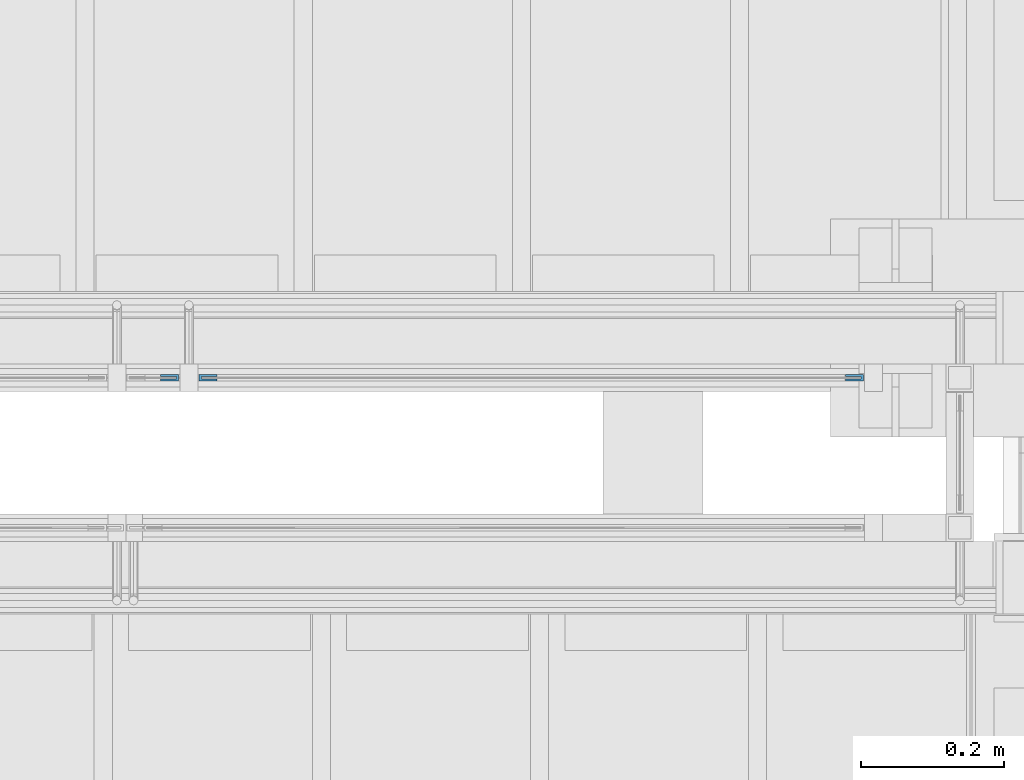
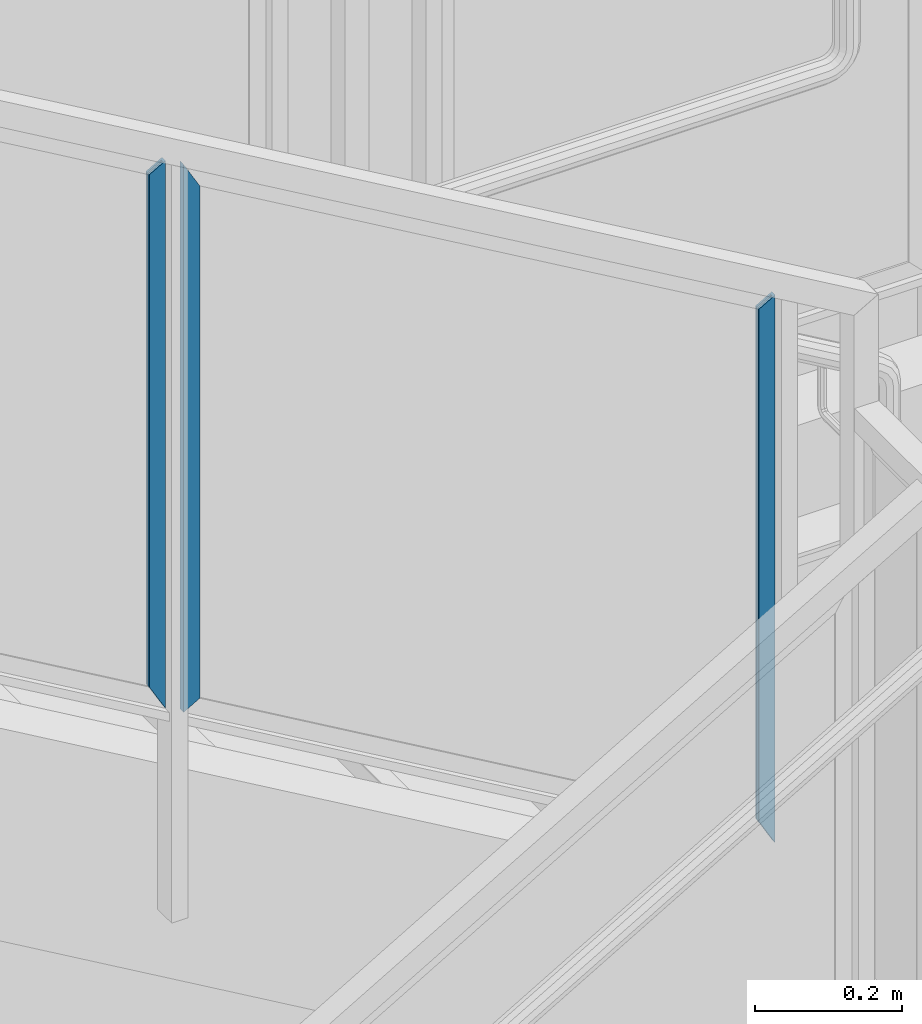
# One storey, part 940 of 1179: 3 beams, 1 element without a shape of its own.
"""IFC2X3 building model written with IfcOpenShell, lengths in millimetres."""

from ifc_helpers import new_model, si_unit, frame, origin_with_axes, place, context, subcontext, project, spatial, faceted_brep, material, type_object, element, aggregate, save


model = new_model("IFC2X3")

# Units and contexts
model_context = context("Model", 3, precision=1e-05, world=origin_with_axes())
body_context = subcontext(model_context, "Body", "Model", "MODEL_VIEW")
ifc_project = project(units=[si_unit("LENGTHUNIT", "METRE", prefix="MILLI"), si_unit("AREAUNIT", "SQUARE_METRE"), si_unit("VOLUMEUNIT", "CUBIC_METRE"), si_unit("MASSUNIT", "GRAM", prefix="KILO"), si_unit("TIMEUNIT", "SECOND"), si_unit("PLANEANGLEUNIT", "RADIAN"), si_unit("SOLIDANGLEUNIT", "STERADIAN"), si_unit("THERMODYNAMICTEMPERATUREUNIT", "DEGREE_CELSIUS"), si_unit("LUMINOUSINTENSITYUNIT", "LUMEN")], contexts=[model_context])

# Site, building, storey
site_placement = place(None, origin_with_axes())
site = spatial("IfcSite", under=ifc_project, at=site_placement, CompositionType="ELEMENT")
building_placement = place(site_placement, origin_with_axes())
building = spatial("IfcBuilding", under=site, at=building_placement, Name="Undefined", CompositionType="ELEMENT")
storey_placement = place(building_placement, origin_with_axes())
storey = spatial("IfcBuildingStorey", under=building, at=storey_placement, Name="Undefined", CompositionType="ELEMENT", Elevation=0.0)

# Assembly, beams
assembly_placement = place(storey_placement, origin_with_axes())
assembly = element("IfcElementAssembly", 1, at=assembly_placement, inside=storey, Name="GUARDRAIL", AssemblyPlace="NOTDEFINED", PredefinedType="RIGID_FRAME")
ifc_material = material(Name="STEEL/BUY-OUT")
beam_type = type_object("IfcBeamType", PredefinedType="NOTDEFINED")
beam_1_placement = place(assembly_placement, frame((21727.2318425017, 39677.9751661883, 7600.2945739131), z_axis=(0.0, 0.0, -1.0), x_axis=(1.0, 0.0, 0.0)))
beam_1 = element("IfcBeam", 2, at=beam_1_placement, type_object=beam_type, material=ifc_material, Name="U-EDGE", context=body_context, shape_type="Brep", body=[
    faceted_brep([(0.0, 1.58750000000146, 410.596656611626), (0.0, -1.58750000000146, 410.596656611626), (22.2250000000131, -1.58750000000146, 449.291208105723), (22.2250000000131, -4.76249999999709, 449.291208105723), (2.91038304567337e-11, -4.76249999999709, 410.596656611676), (2.91038304567337e-11, -7.9375, 410.596656611676), (25.400000000016, -7.9375, 454.819), (25.400000000016, 1.58750000000146, 454.819), (25.400000000016, -7.9375, -454.041889813999), (25.400000000016, 1.58750000000146, -454.041889813999), (0.0, 1.58750000000146, -439.452883390265), (0.0, -1.58750000000146, -439.452883390265), (22.2250000000131, -1.58750000000146, -452.218264011032), (22.2250000000131, -4.76249999999709, -452.218264011032), (2.91038304567337e-11, -4.76249999999709, -439.452883390281), (2.91038304567337e-11, -7.9375, -439.452883390281)], [[[0, 1, 2, 3, 4, 5, 6, 7]], [[7, 6, 8, 9]], [[0, 7, 9, 10]], [[1, 0, 10, 11]], [[2, 1, 11, 12]], [[3, 2, 12, 13]], [[4, 3, 13, 14]], [[5, 4, 14, 15]], [[6, 5, 15, 8]], [[14, 13, 12, 11, 10, 9, 8, 15]]]),
])
beam_2_placement = place(assembly_placement, frame((22683.965176416, 39677.9751661883, 7042.20012977587), z_axis=(0.0, 0.0, -1.0), x_axis=(1.0, 0.0, 0.0)))
beam_2 = element("IfcBeam", 3, at=beam_2_placement, type_object=beam_type, material=ifc_material, Name="U-EDGE", context=body_context, shape_type="Brep", body=[
    faceted_brep([(0.0, 1.58750000000146, 410.596656611626), (0.0, -1.58750000000146, 410.596656611626), (22.2250000000131, -1.58750000000146, 449.291208105723), (22.2250000000131, -4.76249999999709, 449.291208105723), (2.91038304567337e-11, -4.76249999999709, 410.596656611676), (2.91038304567337e-11, -7.9375, 410.596656611676), (25.400000000016, -7.9375, 454.819), (25.400000000016, 1.58750000000146, 454.819), (25.400000000016, -7.9375, -454.041889813999), (25.400000000016, 1.58750000000146, -454.041889813999), (0.0, 1.58750000000146, -439.452883390265), (0.0, -1.58750000000146, -439.452883390265), (22.2250000000131, -1.58750000000146, -452.218264011032), (22.2250000000131, -4.76249999999709, -452.218264011032), (2.91038304567337e-11, -4.76249999999709, -439.452883390281), (2.91038304567337e-11, -7.9375, -439.452883390281)], [[[0, 1, 2, 3, 4, 5, 6, 7]], [[7, 6, 8, 9]], [[0, 7, 9, 10]], [[1, 0, 10, 11]], [[2, 1, 11, 12]], [[3, 2, 12, 13]], [[4, 3, 13, 14]], [[5, 4, 14, 15]], [[6, 5, 15, 8]], [[14, 13, 12, 11, 10, 9, 8, 15]]]),
])
beam_3_placement = place(assembly_placement, frame((21806.4291677555, 39677.9751661883, 7582.95235736053), z_axis=(0.0, 0.0, -1.0), x_axis=(-1.0, 0.0, 0.0)))
beam_3 = element("IfcBeam", 4, at=beam_3_placement, type_object=beam_type, material=ifc_material, Name="U-EDGE", context=body_context, shape_type="Brep", body=[
    faceted_brep([(2.91038304567337e-11, 7.9375, 439.454484500298), (25.400000000016, 7.9375, 454.043488866833), (25.400000000016, 7.9375, -454.819), (2.91038304567337e-11, 7.9375, -410.596660287256), (2.91038304567337e-11, 4.76249999999709, 439.454484500298), (2.91038304567337e-11, 4.76249999999709, -410.596660287256), (22.2250000000131, 4.76249999999709, 452.219863321016), (22.2250000000131, 4.76249999999709, -449.290437478487), (22.2250000000131, 1.58750000000146, 452.219863321016), (22.2250000000131, 1.58750000000146, -449.290437478487), (0.0, 1.58750000000146, 439.454484500282), (0.0, 1.58750000000146, -410.596660287205), (0.0, -1.58750000000146, 439.454484500282), (0.0, -1.58750000000146, -410.596660287205), (25.400000000016, -1.58750000000146, 454.043488866833), (25.400000000016, -1.58750000000146, -454.819)], [[[0, 1, 2, 3]], [[4, 0, 3, 5]], [[6, 4, 5, 7]], [[8, 6, 7, 9]], [[10, 8, 9, 11]], [[12, 10, 11, 13]], [[14, 12, 13, 15]], [[11, 9, 7, 5, 3, 2, 15, 13]], [[1, 14, 15, 2]], [[0, 4, 6, 8, 10, 12, 14, 1]]]),
])
aggregate(assembly, [beam_1, beam_2, beam_3])

save(model, "model.ifc")
